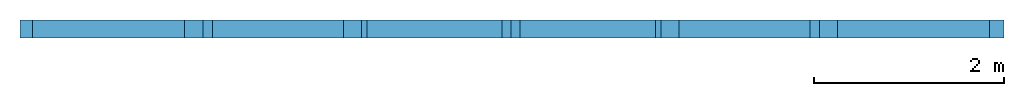
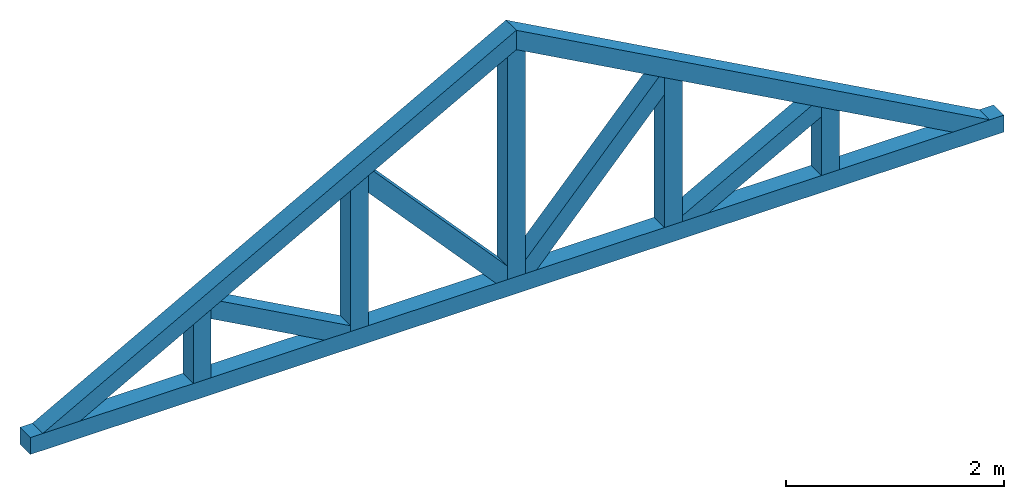
# One storey: 12 beams.
"""IFC2X3 building model written with IfcOpenShell, lengths in metres."""

from ifc_helpers import new_model, entity, si_unit, converted_unit, derived_unit, direction, frame, frame_2d, origin, origin_2d_with_axis, place, context, subcontext, project, spatial, rectangle, extrude, clip, halfspace, material, type_object, element, save


model = new_model("IFC2X3")

# Units and contexts
model_context = context("Model", 3, precision=1e-05, world=origin(), true_north=direction((6.12303176911189e-17, 1.0)))
body_context = subcontext(model_context, "Body", "Model", "MODEL_VIEW")
ifc_project = project(units=[si_unit("LENGTHUNIT", "METRE"), si_unit("AREAUNIT", "SQUARE_METRE"), si_unit("VOLUMEUNIT", "CUBIC_METRE"), converted_unit("PLANEANGLEUNIT", "DEGREE", entity("IfcRatioMeasure", 0.0174532925199433), si_unit("PLANEANGLEUNIT", "RADIAN"), dimensions=[0, 0, 0, 0, 0, 0, 0]), si_unit("MASSUNIT", "GRAM", prefix="KILO"), derived_unit("MASSDENSITYUNIT", [(si_unit("MASSUNIT", "GRAM", prefix="KILO"), 1), (si_unit("LENGTHUNIT", "METRE"), -3)]), derived_unit("MOMENTOFINERTIAUNIT", [(si_unit("LENGTHUNIT", "METRE"), 4)]), si_unit("TIMEUNIT", "SECOND"), si_unit("FREQUENCYUNIT", "HERTZ"), si_unit("THERMODYNAMICTEMPERATUREUNIT", "DEGREE_CELSIUS"), derived_unit("THERMALTRANSMITTANCEUNIT", [(si_unit("MASSUNIT", "GRAM", prefix="KILO"), 1), (si_unit("THERMODYNAMICTEMPERATUREUNIT", "KELVIN"), -1), (si_unit("TIMEUNIT", "SECOND"), -3)]), derived_unit("VOLUMETRICFLOWRATEUNIT", [(si_unit("LENGTHUNIT", "METRE"), 3), (si_unit("TIMEUNIT", "SECOND"), -1)]), si_unit("ELECTRICCURRENTUNIT", "AMPERE"), si_unit("ELECTRICVOLTAGEUNIT", "VOLT"), si_unit("POWERUNIT", "WATT"), si_unit("FORCEUNIT", "NEWTON", prefix="KILO"), si_unit("ILLUMINANCEUNIT", "LUX"), si_unit("LUMINOUSFLUXUNIT", "LUMEN"), si_unit("LUMINOUSINTENSITYUNIT", "CANDELA"), derived_unit("USERDEFINED", [(si_unit("MASSUNIT", "GRAM", prefix="KILO"), -1), (si_unit("LENGTHUNIT", "METRE"), -2), (si_unit("TIMEUNIT", "SECOND"), 3), (si_unit("LUMINOUSFLUXUNIT", "LUMEN"), 1)]), derived_unit("LINEARVELOCITYUNIT", [(si_unit("LENGTHUNIT", "METRE"), 1), (si_unit("TIMEUNIT", "SECOND"), -1)]), si_unit("PRESSUREUNIT", "PASCAL"), derived_unit("USERDEFINED", [(si_unit("LENGTHUNIT", "METRE"), -2), (si_unit("MASSUNIT", "GRAM", prefix="KILO"), 1), (si_unit("TIMEUNIT", "SECOND"), -2)]), derived_unit("LINEARFORCEUNIT", [(si_unit("MASSUNIT", "GRAM", prefix="KILO"), 1), (si_unit("LENGTHUNIT", "METRE"), 1), (si_unit("TIMEUNIT", "SECOND"), -2), (si_unit("LENGTHUNIT", "METRE"), -1)]), derived_unit("PLANARFORCEUNIT", [(si_unit("MASSUNIT", "GRAM", prefix="KILO"), 1), (si_unit("LENGTHUNIT", "METRE"), 1), (si_unit("TIMEUNIT", "SECOND"), -2), (si_unit("LENGTHUNIT", "METRE"), -2)])], contexts=[model_context])

# Site, building, storey
site_placement = place(None, origin())
site = spatial("IfcSite", under=ifc_project, at=site_placement, CompositionType="ELEMENT")
building_placement = place(site_placement, origin())
building = spatial("IfcBuilding", under=site, at=building_placement, CompositionType="ELEMENT")
storey_placement = place(building_placement, frame((0.0, 0.0, 4.0)))
storey = spatial("IfcBuildingStorey", under=building, at=storey_placement, Name="Nivel 2", CompositionType="ELEMENT", Elevation=4.0)

# Beams
ifc_material = material()
beam_type = type_object("IfcBeamType", Name="Madera:184x184", PredefinedType="NOTDEFINED")
beam_1_placement = place(storey_placement, frame((-6.13957987662146, 0.151056277905034, 0.0)))
element("IfcBeam", 1, at=beam_1_placement, inside=storey, type_object=beam_type, material=ifc_material, Name="Madera:184x184", ObjectType="Madera:184x184", context=body_context, shape_type="SweptSolid", body=[
    extrude(rectangle(XDim=0.1905, YDim=0.190500000000003, at=frame_2d((0.0, 3.34177130412172e-14), x_axis=(1.0, 0.0))), frame((-0.157283484785403, 0.0, 0.0), z_axis=(1.0, 0.0, 0.0), x_axis=(0.0, 0.0, -1.0)), (0.0, 0.0, 1.0), 10.3323122557959),
])
beam_2_placement = place(storey_placement, frame((-6.13957987662146, 0.151056277905034, 0.0), z_axis=(-0.481918749772156, 0.0, 0.876215908676647), x_axis=(0.876215908676647, 0.0, 0.481918749772156)))
element("IfcBeam", 2, at=beam_2_placement, inside=storey, type_object=beam_type, material=ifc_material, Name="Madera:184x184", ObjectType="Madera:184x184", context=body_context, shape_type="Clipping", body=[
    clip(clip(extrude(rectangle(XDim=0.1905, YDim=0.190500000000003, at=frame_2d((0.0, -3.46944695195361e-17), x_axis=(1.0, 0.0))), frame((0.0244656069184313, 0.0, 0.0), z_axis=(1.0, 0.0, 0.0), x_axis=(0.0, 0.0, -1.0)), (0.0, 0.0, 1.0), 5.73427799833823), halfspace(frame((-0.0919115306252767, -0.0952500000000044, 0.159257425649036), z_axis=(-0.481918749772156, 0.0, -0.876215908676647), x_axis=(0.876215908676647, 0.0, -0.481918749772156)), False)), halfspace(frame((5.75874360525666, 0.0, 0.0952499999999957), z_axis=(0.876215908676647, 0.0, -0.481918749772156), x_axis=(0.0, -1.0, 0.0)), False)),
])
beam_3_placement = place(storey_placement, frame((-1.13957987662147, 0.151056277905018, 2.75), z_axis=(0.481918749772156, 0.0, 0.876215908676647), x_axis=(0.876215908676647, 0.0, -0.481918749772156)))
element("IfcBeam", 3, at=beam_3_placement, inside=storey, type_object=beam_type, material=ifc_material, Name="Madera:184x184", ObjectType="Madera:184x184", context=body_context, shape_type="Clipping", body=[
    clip(clip(extrude(rectangle(XDim=0.1905, YDim=0.190500000000003, at=frame_2d((3.46944695195361e-17, 3.46944695195361e-17), x_axis=(1.0, 0.0))), frame((-0.0523875000000011, 0.0, 0.0), z_axis=(1.0, 0.0, 0.0), x_axis=(0.0, 0.0, -1.0)), (0.0, 0.0, 1.0), 5.73427799833823), halfspace(frame((-3.23952003396667, -0.0952500000000044, -4.8115257927677), z_axis=(0.481918749772156, 0.0, -0.876215908676647), x_axis=(0.876215908676647, 0.0, 0.481918749772156)), False)), halfspace(frame((-0.0523874999999989, 0.0, 0.0952499999999968), z_axis=(-0.876215908676648, 0.0, -0.481918749772154), x_axis=(0.0, 1.0, 0.0)), False)),
])
beam_4_placement = place(storey_placement, frame((-1.13957987662147, 0.151056277905018, 0.0), z_axis=(1.0, 0.0, 0.0), x_axis=(0.0, 0.0, 1.0)))
element("IfcBeam", 4, at=beam_4_placement, inside=storey, type_object=beam_type, material=ifc_material, Name="Madera:184x184", ObjectType="Madera:184x184", context=body_context, shape_type="Clipping", body=[
    clip(clip(extrude(rectangle(XDim=0.190500000000003, YDim=0.1905, at=frame_2d((0.0, 6.93889390390723e-17), x_axis=(1.0, 0.0))), frame((0.0952499999999946, 0.0, 0.0), z_axis=(1.0, 0.0, 0.0), x_axis=(0.0, 1.0, 0.0)), (0.0, 0.0, 1.0), 2.54604391619486), halfspace(frame((-0.255997663882079, -0.095250000000016, -5.26780287286715), z_axis=(0.876215908676647, 0.0, -0.481918749772156), x_axis=(0.481918749772156, 0.0, 0.876215908676647)), False)), halfspace(frame((2.6664546277985, -0.0952499999999991, -0.0457467483702742), z_axis=(0.876215908676647, 0.0, 0.481918749772156), x_axis=(-0.481918749772156, 0.0, 0.876215908676647)), False)),
])
beam_5_placement = place(storey_placement, frame((-2.80624654328813, 0.151056277905023, 0.0), z_axis=(1.0, 0.0, 0.0), x_axis=(0.0, 0.0, 1.0)))
element("IfcBeam", 5, at=beam_5_placement, inside=storey, type_object=beam_type, material=ifc_material, Name="Madera:184x184", ObjectType="Madera:184x184", context=body_context, shape_type="Clipping", body=[
    clip(extrude(rectangle(XDim=0.190500000000001, YDim=0.190500000000003, at=frame_2d((-5.41233724504764e-16, 0.0), x_axis=(1.0, 0.0))), frame((0.0952499999999946, 0.0, 0.0), z_axis=(1.0, 0.0, 0.0), x_axis=(0.0, 0.0, -1.0)), (0.0, 0.0, 1.0), 1.68176474952819), halfspace(frame((-0.255997663882079, -0.0952500000000106, -3.60113620620049), z_axis=(0.876215908676647, 0.0, -0.481918749772156), x_axis=(0.481918749772156, 0.0, 0.876215908676647)), False)),
])
beam_6_placement = place(storey_placement, frame((-4.47291320995479, 0.151056277905029, 0.0), z_axis=(1.0, 0.0, 0.0), x_axis=(0.0, 0.0, 1.0)))
element("IfcBeam", 6, at=beam_6_placement, inside=storey, type_object=beam_type, material=ifc_material, Name="Madera:184x184", ObjectType="Madera:184x184", context=body_context, shape_type="Clipping", body=[
    clip(extrude(rectangle(XDim=0.190500000000001, YDim=0.190500000000003, at=origin_2d_with_axis()), frame((0.0952499999999946, 0.0, 0.0), z_axis=(1.0, 0.0, 0.0), x_axis=(0.0, 0.0, -1.0)), (0.0, 0.0, 1.0), 0.765098082861528), halfspace(frame((-0.255997663882079, -0.0952500000000052, -1.93446953953382), z_axis=(0.876215908676647, 0.0, -0.481918749772156), x_axis=(0.481918749772156, 0.0, 0.876215908676647)), False)),
])
beam_7_placement = place(storey_placement, frame((0.527086790045196, 0.151056277905013, 0.0), z_axis=(1.0, 0.0, 0.0), x_axis=(0.0, 0.0, 1.0)))
element("IfcBeam", 7, at=beam_7_placement, inside=storey, type_object=beam_type, material=ifc_material, Name="Madera:184x184", ObjectType="Madera:184x184", context=body_context, shape_type="Clipping", body=[
    clip(extrude(rectangle(XDim=0.1905, YDim=0.190500000000003, at=origin_2d_with_axis()), frame((0.0952499999999946, 0.0, 0.0), z_axis=(1.0, 0.0, 0.0), x_axis=(0.0, 0.0, -1.0)), (0.0, 0.0, 1.0), 1.6817647495282), halfspace(frame((2.6664546277985, -0.0952500000000045, -1.71241341503694), z_axis=(0.876215908676647, 0.0, 0.481918749772156), x_axis=(-0.481918749772156, 0.0, 0.876215908676647)), False)),
])
beam_8_placement = place(storey_placement, frame((2.19375345671186, 0.151056277905007, -0.50333333333333), z_axis=(1.0, 0.0, 0.0), x_axis=(0.0, 0.0, 1.0)))
element("IfcBeam", 8, at=beam_8_placement, inside=storey, type_object=beam_type, material=ifc_material, Name="Madera:184x184", ObjectType="Madera:184x184", context=body_context, shape_type="Clipping", body=[
    clip(extrude(rectangle(XDim=0.190500000000001, YDim=0.190500000000003, at=origin_2d_with_axis()), frame((0.598583333333324, 0.0, 0.0), z_axis=(1.0, 0.0, 0.0), x_axis=(0.0, 0.0, -1.0)), (0.0, 0.0, 1.0), 0.765098082861533), halfspace(frame((3.16978796113183, -0.0952500000000099, -3.3790800817036), z_axis=(0.876215908676647, 0.0, 0.481918749772156), x_axis=(-0.481918749772156, 0.0, 0.876215908676647)), False)),
])
beam_9_placement = place(storey_placement, frame((-2.80624654328813, 0.151056277905023, 1.83333333333333), z_axis=(0.739940073395945, 0.0, 0.672672793996311), x_axis=(0.672672793996311, 0.0, -0.739940073395945)))
element("IfcBeam", 9, at=beam_9_placement, inside=storey, type_object=beam_type, material=ifc_material, Name="Madera:184x184", ObjectType="Madera:184x184", context=body_context, shape_type="Clipping", body=[
    clip(clip(clip(clip(extrude(rectangle(XDim=0.190500000000002, YDim=0.190500000000003, at=frame_2d((0.0, 3.95516952522712e-16), x_axis=(0.0, 1.0))), frame((0.10574446066248, 0.0, 0.0), z_axis=(1.0, 0.0, 0.0), x_axis=(0.0, 1.0, 0.0)), (0.0, 0.0, 1.0), 2.23738228827149), halfspace(frame((-1.06196545857951, -0.095249999999988, -3.75200863662766), z_axis=(0.739940073395945, 0.0, -0.672672793996311), x_axis=(0.672672793996311, 0.0, 0.739940073395945)), False)), halfspace(frame((1.66580466223956, 0.0952500000000103, -1.38564123401941), z_axis=(-0.672672793996311, 0.0, -0.739940073395945), x_axis=(-0.739940073395945, 0.0, 0.672672793996311)), False)), halfspace(frame((2.56456056373413, -0.0952499999999979, -0.207710676362968), z_axis=(0.672672793996311, 0.0, 0.739940073395945), x_axis=(-0.739940073395945, 0.0, 0.672672793996311)), False)), halfspace(frame((-0.876406621958164, 0.0952500000000168, -4.07006110820477), z_axis=(-0.972520895665338, 0.0, 0.232815608356246), x_axis=(0.232815608356246, 0.0, 0.972520895665338)), False)),
])
beam_10_placement = place(storey_placement, frame((-4.47291320995479, 0.151056277905029, 0.916666666666668), z_axis=(0.481918749772157, 0.0, 0.876215908676647), x_axis=(0.876215908676647, 0.0, -0.481918749772157)))
element("IfcBeam", 10, at=beam_10_placement, inside=storey, type_object=beam_type, material=ifc_material, Name="Madera:184x184", ObjectType="Madera:184x184", context=body_context, shape_type="Clipping", body=[
    clip(clip(clip(clip(extrude(rectangle(XDim=0.190500000000001, YDim=0.190500000000003, at=frame_2d((-4.16333634234434e-17, 2.35922392732846e-16), x_axis=(0.0, 1.0))), frame((0.110600546797761, 0.0, 0.0), z_axis=(1.0, 0.0, 0.0), x_axis=(0.0, 1.0, 0.0)), (0.0, 0.0, 1.0), 1.66215582873721), halfspace(frame((-1.20231804629347, -0.0952500000000044, -1.59873412762), z_axis=(0.481918749772157, 0.0, -0.876215908676647), x_axis=(0.876215908676647, 0.0, 0.481918749772157)), False)), halfspace(frame((0.685148996136544, 0.0952500000000043, -1.04807802242074), z_axis=(-0.876215908676647, 0.0, -0.481918749772157), x_axis=(-0.481918749772157, 0.0, 0.876215908676647)), False)), halfspace(frame((1.978340721974, -0.0952499999999988, -0.336232916412589), z_axis=(0.876215908676647, 0.0, 0.481918749772157), x_axis=(-0.481918749772157, 0.0, 0.876215908676647)), False)), halfspace(frame((-1.12988405730947, 0.095249999999999, -1.95976428392892), z_axis=(-0.844529750479847, 0.0, 0.535508637236083), x_axis=(0.535508637236083, 0.0, 0.844529750479847)), False)),
])
beam_11_placement = place(storey_placement, frame((-1.13957987662147, 0.151056277905018, 0.0), z_axis=(0.739940073395945, 0.0, -0.672672793996311), x_axis=(0.672672793996311, 0.0, 0.739940073395945)))
element("IfcBeam", 11, at=beam_11_placement, inside=storey, type_object=beam_type, material=ifc_material, Name="Madera:184x184", ObjectType="Madera:184x184", context=body_context, shape_type="Clipping", body=[
    clip(clip(clip(clip(extrude(rectangle(XDim=0.190500000000001, YDim=0.190500000000003, at=frame_2d((1.38777878078145e-17, -2.91433543964104e-16), x_axis=(0.0, 1.0))), frame((0.134551375619105, 0.0, 0.0), z_axis=(1.0, 0.0, 0.0), x_axis=(0.0, 1.0, 0.0)), (0.0, 0.0, 1.0), 2.23738228827149), halfspace(frame((-3.39868499915067, 0.0952499999999875, -3.88015280388395), z_axis=(-0.739940073395945, 0.0, 0.672672793996311), x_axis=(0.672672793996311, 0.0, 0.739940073395945)), False)), halfspace(frame((-0.0868824391810546, -0.0952500000000033, 0.20771067636296), z_axis=(-0.672672793996311, 0.0, -0.739940073395945), x_axis=(0.739940073395945, 0.0, -0.672672793996311)), False)), halfspace(frame((0.856868935622934, 0.0952500000000047, 1.34473625828357), z_axis=(0.672672793996311, 0.0, 0.739940073395945), x_axis=(0.739940073395945, 0.0, -0.672672793996311)), False)), halfspace(frame((1.9422440399577, -0.0952500000000069, -1.82750133689234), z_axis=(0.972520895665338, 0.0, -0.232815608356246), x_axis=(0.232815608356246, 0.0, 0.972520895665338)), False)),
])
beam_12_placement = place(storey_placement, frame((0.527086790045196, 0.151056277905013, 0.0), z_axis=(-0.481918749772158, 0.0, 0.876215908676646), x_axis=(0.876215908676646, 0.0, 0.481918749772158)))
element("IfcBeam", 12, at=beam_12_placement, inside=storey, type_object=beam_type, material=ifc_material, Name="Madera:184x184", ObjectType="Madera:184x184", context=body_context, shape_type="Clipping", body=[
    clip(clip(clip(clip(extrude(rectangle(XDim=0.1905, YDim=0.190500000000003, at=frame_2d((-6.93889390390723e-18, -3.46944695195361e-17), x_axis=(0.0, 1.0))), frame((0.12936232621724, 0.0, 0.0), z_axis=(1.0, 0.0, 0.0), x_axis=(0.0, 1.0, 0.0)), (0.0, 0.0, 1.0), 1.66215582873721), halfspace(frame((-5.93335092180291, -0.0952500000000044, 3.37204909079675), z_axis=(-0.481918749772158, 0.0, -0.876215908676646), x_axis=(0.876215908676646, 0.0, -0.481918749772158)), False)), halfspace(frame((-0.0469167250738178, 0.0952500000000043, -0.282950561598091), z_axis=(-0.876215908676646, 0.0, 0.481918749772158), x_axis=(0.481918749772158, 0.0, 0.876215908676646)), False)), halfspace(frame((1.1343345117743, -0.0952499999999988, -1.19832382940504), z_axis=(0.876215908676646, 0.0, -0.481918749772158), x_axis=(0.481918749772158, 0.0, 0.876215908676646)), False)), halfspace(frame((-0.21542939593383, 0.095249999999999, 3.16163409670919), z_axis=(0.844529750479847, 0.0, 0.535508637236083), x_axis=(0.535508637236083, 0.0, -0.844529750479847)), False)),
])

save(model, "model.ifc")
